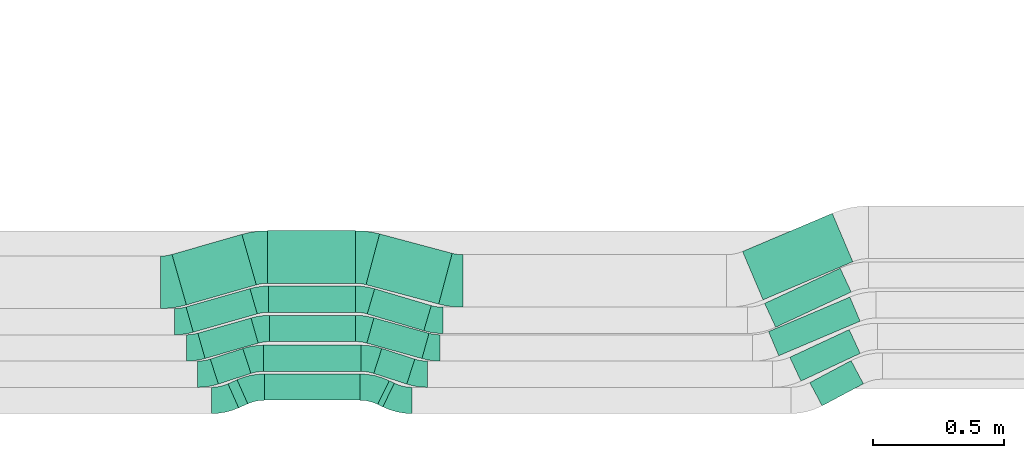
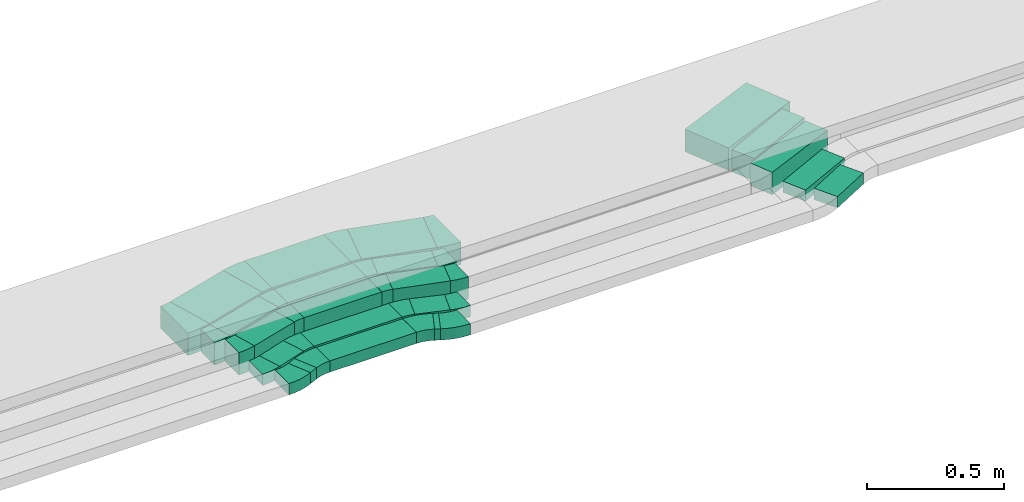
# One storey, part 15 of 28: 20 flow fittings, 20 flow segments.
"""IFC2X3 building model written with IfcOpenShell, lengths in millimetres."""

from ifc_helpers import new_model, entity, si_unit, converted_unit, derived_unit, direction, frame, frame_2d, origin, origin_2d_with_axis, place, context, subcontext, project, spatial, polyline, circle_curve, parameter, trimmed, segment, composite_curve, rectangle, outline, extrude, source, transform, mapped, material, type_object, type_shapes, element, save


model = new_model("IFC2X3")

# Units and contexts
model_context = context("Model", 3, precision=0.01, world=origin(), true_north=direction((6.12303176911189e-17, 1.0)))
body_context = subcontext(model_context, "Body", "Model", "MODEL_VIEW")
ifc_project = project(units=[si_unit("LENGTHUNIT", "METRE", prefix="MILLI"), si_unit("AREAUNIT", "SQUARE_METRE"), si_unit("VOLUMEUNIT", "CUBIC_METRE"), converted_unit("PLANEANGLEUNIT", "DEGREE", entity("IfcRatioMeasure", 0.0174532925199433), si_unit("PLANEANGLEUNIT", "RADIAN"), dimensions=[0, 0, 0, 0, 0, 0, 0]), si_unit("MASSUNIT", "GRAM", prefix="KILO"), derived_unit("MASSDENSITYUNIT", [(si_unit("MASSUNIT", "GRAM", prefix="KILO"), 1), (si_unit("LENGTHUNIT", "METRE"), -3)]), derived_unit("MOMENTOFINERTIAUNIT", [(si_unit("LENGTHUNIT", "METRE"), 4)]), si_unit("TIMEUNIT", "SECOND"), si_unit("FREQUENCYUNIT", "HERTZ"), si_unit("THERMODYNAMICTEMPERATUREUNIT", "DEGREE_CELSIUS"), derived_unit("THERMALTRANSMITTANCEUNIT", [(si_unit("MASSUNIT", "GRAM", prefix="KILO"), 1), (si_unit("THERMODYNAMICTEMPERATUREUNIT", "KELVIN"), -1), (si_unit("TIMEUNIT", "SECOND"), -3)]), derived_unit("VOLUMETRICFLOWRATEUNIT", [(si_unit("LENGTHUNIT", "METRE"), 3), (si_unit("TIMEUNIT", "SECOND"), -1)]), derived_unit("MASSFLOWRATEUNIT", [(si_unit("MASSUNIT", "GRAM", prefix="KILO"), 1), (si_unit("TIMEUNIT", "SECOND"), -1)]), derived_unit("ROTATIONALFREQUENCYUNIT", [(si_unit("TIMEUNIT", "SECOND"), -1)]), si_unit("ELECTRICCURRENTUNIT", "AMPERE"), si_unit("ELECTRICVOLTAGEUNIT", "VOLT"), si_unit("POWERUNIT", "WATT"), si_unit("FORCEUNIT", "NEWTON", prefix="KILO"), si_unit("ILLUMINANCEUNIT", "LUX"), si_unit("LUMINOUSFLUXUNIT", "LUMEN"), si_unit("LUMINOUSINTENSITYUNIT", "CANDELA"), derived_unit("USERDEFINED", [(si_unit("MASSUNIT", "GRAM", prefix="KILO"), -1), (si_unit("LENGTHUNIT", "METRE"), -2), (si_unit("TIMEUNIT", "SECOND"), 3), (si_unit("LUMINOUSFLUXUNIT", "LUMEN"), 1)]), derived_unit("LINEARVELOCITYUNIT", [(si_unit("LENGTHUNIT", "METRE"), 1), (si_unit("TIMEUNIT", "SECOND"), -1)]), si_unit("PRESSUREUNIT", "PASCAL"), derived_unit("USERDEFINED", [(si_unit("LENGTHUNIT", "METRE"), -2), (si_unit("MASSUNIT", "GRAM", prefix="KILO"), 1), (si_unit("TIMEUNIT", "SECOND"), -2)]), derived_unit("LINEARFORCEUNIT", [(si_unit("MASSUNIT", "GRAM", prefix="KILO"), 1), (si_unit("LENGTHUNIT", "METRE"), 1), (si_unit("TIMEUNIT", "SECOND"), -2), (si_unit("LENGTHUNIT", "METRE"), -1)]), derived_unit("PLANARFORCEUNIT", [(si_unit("MASSUNIT", "GRAM", prefix="KILO"), 1), (si_unit("LENGTHUNIT", "METRE"), 1), (si_unit("TIMEUNIT", "SECOND"), -2), (si_unit("LENGTHUNIT", "METRE"), -2)])], contexts=[model_context])

# Site, building, storey
site_placement = place(None, origin())
site = spatial("IfcSite", under=ifc_project, at=site_placement, CompositionType="ELEMENT")
building_placement = place(site_placement, origin())
building = spatial("IfcBuilding", under=site, at=building_placement, CompositionType="ELEMENT")
storey_placement = place(building_placement, frame((0.0, 0.0, 4200.0)))
storey = spatial("IfcBuildingStorey", under=building, at=storey_placement, CompositionType="ELEMENT", Elevation=4200.0)

# Flow segments
cable_carrier_segment_type = type_object("IfcCableCarrierSegmentType", PredefinedType="CABLETRAYSEGMENT")
flow_segment_1_placement = place(storey_placement, frame((34682.3, 268.68, 2836.0)))
element("IfcFlowSegment", 1, at=flow_segment_1_placement, inside=storey, type_object=cable_carrier_segment_type, context=body_context, shape_type="SweptSolid", body=[
    extrude(rectangle(XDim=37.9773753319745, YDim=100.000000000002, at=origin_2d_with_axis()), frame((37.68, 53.4, 0.0), z_axis=(0.0, 0.0, 1.0), x_axis=(0.913545457642342, 0.406736643076381, 0.0)), (0.0, 0.0, 1.0), 49.9999999999995),
])
flow_segment_2_placement = place(storey_placement, frame((34820.59, 297.5, 2836.0)))
element("IfcFlowSegment", 2, at=flow_segment_2_placement, inside=storey, type_object=cable_carrier_segment_type, context=body_context, shape_type="SweptSolid", body=[
    extrude(rectangle(XDim=364.315049440889, YDim=100.0, at=origin_2d_with_axis()), frame((182.16, 50.0, 0.0)), (0.0, 0.0, 1.0), 49.9999999999995),
])
flow_segment_3_placement = place(storey_placement, frame((35252.56, 272.4, 2836.0)))
element("IfcFlowSegment", 3, at=flow_segment_3_placement, inside=storey, type_object=cable_carrier_segment_type, context=body_context, shape_type="SweptSolid", body=[
    extrude(rectangle(XDim=21.632255407363, YDim=99.9999999999977, at=origin_2d_with_axis()), frame((31.64, 49.68, 0.0), z_axis=(0.0, 0.0, 1.0), x_axis=(-0.898794046298938, 0.438371146789548, 0.0)), (0.0, 0.0, 1.0), 49.9999999999995),
])
flow_segment_4_placement = place(storey_placement, frame((34614.95, 359.2, 2836.0)))
element("IfcFlowSegment", 4, at=flow_segment_4_placement, inside=storey, type_object=cable_carrier_segment_type, context=body_context, shape_type="SweptSolid", body=[
    extrude(rectangle(XDim=130.375714038921, YDim=100.0, at=origin_2d_with_axis()), frame((77.45, 67.7, 0.0), z_axis=(0.0, 0.0, 1.0), x_axis=(0.951056516295102, 0.309016994375106, 0.0)), (0.0, 0.0, 1.0), 49.9999999999995),
])
flow_segment_5_placement = place(storey_placement, frame((34818.15, 407.14, 2836.0)))
element("IfcFlowSegment", 5, at=flow_segment_5_placement, inside=storey, type_object=cable_carrier_segment_type, context=body_context, shape_type="SweptSolid", body=[
    extrude(rectangle(XDim=371.2003762548, YDim=100.0, at=origin_2d_with_axis()), frame((185.6, 50.0, 0.0)), (0.0, 0.0, 1.0), 49.9999999999995),
])
flow_segment_6_placement = place(storey_placement, frame((35237.35, 359.03, 2836.0)))
element("IfcFlowSegment", 6, at=flow_segment_6_placement, inside=storey, type_object=cable_carrier_segment_type, context=body_context, shape_type="SweptSolid", body=[
    extrude(rectangle(XDim=132.114181843629, YDim=99.9999999999975, at=origin_2d_with_axis()), frame((78.22, 67.86, 0.0), z_axis=(0.0, 0.0, 1.0), x_axis=(-0.951716267923426, 0.306979063406458, 0.0)), (0.0, 0.0, 1.0), 49.9999999999995),
])
flow_segment_7_placement = place(storey_placement, frame((34567.56, 456.62, 2836.0)))
element("IfcFlowSegment", 7, at=flow_segment_7_placement, inside=storey, type_object=cable_carrier_segment_type, context=body_context, shape_type="SweptSolid", body=[
    extrude(rectangle(XDim=210.504113333605, YDim=100.000000000001, at=origin_2d_with_axis()), frame((114.96, 77.07, 0.0), z_axis=(0.0, 0.0, 1.0), x_axis=(0.961261695938295, 0.275637355817084, 0.0)), (0.0, 0.0, 1.0), 100.000000000001),
])
flow_segment_8_placement = place(storey_placement, frame((34840.78, 520.73, 2836.0)))
element("IfcFlowSegment", 8, at=flow_segment_8_placement, inside=storey, type_object=cable_carrier_segment_type, context=body_context, shape_type="SweptSolid", body=[
    extrude(rectangle(XDim=328.015010459565, YDim=100.0, at=origin_2d_with_axis()), frame((164.01, 50.0, 0.0)), (0.0, 0.0, 1.0), 100.000000000001),
])
flow_segment_9_placement = place(storey_placement, frame((35211.2, 456.18, 2836.0)))
element("IfcFlowSegment", 9, at=flow_segment_9_placement, inside=storey, type_object=cable_carrier_segment_type, context=body_context, shape_type="SweptSolid", body=[
    extrude(rectangle(XDim=217.79615928682, YDim=100.000000000001, at=origin_2d_with_axis()), frame((118.35, 77.51, 0.0), z_axis=(0.0, 0.0, 1.0), x_axis=(-0.962971294356607, 0.269603943304174, 0.0)), (0.0, 0.0, 1.0), 100.000000000001),
])
flow_segment_10_placement = place(storey_placement, frame((34522.66, 556.62, 2836.0)))
element("IfcFlowSegment", 10, at=flow_segment_10_placement, inside=storey, type_object=cable_carrier_segment_type, context=body_context, shape_type="SweptSolid", body=[
    extrude(rectangle(XDim=253.294448744535, YDim=99.9999999999999, at=origin_2d_with_axis()), frame((135.52, 82.97, 0.0), z_axis=(0.0, 0.0, 1.0), x_axis=(0.961261695938265, 0.275637355817187, 0.0)), (0.0, 0.0, 1.0), 100.000000000001),
])
flow_segment_11_placement = place(storey_placement, frame((34837.01, 632.52, 2836.0)))
element("IfcFlowSegment", 11, at=flow_segment_11_placement, inside=storey, type_object=cable_carrier_segment_type, context=body_context, shape_type="SweptSolid", body=[
    extrude(rectangle(XDim=331.015908531008, YDim=100.0, at=origin_2d_with_axis()), frame((165.51, 50.0, 0.0)), (0.0, 0.0, 1.0), 100.000000000001),
])
flow_segment_12_placement = place(storey_placement, frame((35212.58, 562.23, 2836.0)))
element("IfcFlowSegment", 12, at=flow_segment_12_placement, inside=storey, type_object=cable_carrier_segment_type, context=body_context, shape_type="SweptSolid", body=[
    extrude(rectangle(XDim=224.770694209987, YDim=99.9999999999985, at=origin_2d_with_axis()), frame((121.96, 79.86, 0.0), z_axis=(0.0, 0.0, 1.0), x_axis=(0.958832135501793, -0.283973477509911, 0.0)), (0.0, 0.0, 1.0), 100.000000000002),
])
flow_segment_13_placement = place(storey_placement, frame((34468.99, 660.49, 2836.0)))
element("IfcFlowSegment", 13, at=flow_segment_13_placement, inside=storey, type_object=cable_carrier_segment_type, context=body_context, shape_type="SweptSolid", body=[
    extrude(rectangle(XDim=277.030700685204, YDim=200.000000000003, at=origin_2d_with_axis()), frame((160.71, 134.31, 0.0), z_axis=(0.0, 0.0, 1.0), x_axis=(0.961261695938271, 0.275637355817165, 0.0)), (0.0, 0.0, 1.0), 100.000000000001),
])
flow_segment_14_placement = place(storey_placement, frame((34833.73, 742.94, 2836.0)))
element("IfcFlowSegment", 14, at=flow_segment_14_placement, inside=storey, type_object=cable_carrier_segment_type, context=body_context, shape_type="SweptSolid", body=[
    extrude(rectangle(XDim=333.654743209258, YDim=200.0, at=origin_2d_with_axis()), frame((166.83, 100.0, 0.0)), (0.0, 0.0, 1.0), 100.000000000001),
])
flow_segment_15_placement = place(storey_placement, frame((35208.04, 663.76, 2836.0)))
element("IfcFlowSegment", 15, at=flow_segment_15_placement, inside=storey, type_object=cable_carrier_segment_type, context=body_context, shape_type="SweptSolid", body=[
    extrude(rectangle(XDim=286.296046062282, YDim=199.999999999998, at=origin_2d_with_axis()), frame((164.1, 133.54, 0.0), z_axis=(0.0, 0.0, 1.0), x_axis=(0.966162315070978, -0.257934838547816, 0.0)), (0.0, 0.0, 1.0), 100.0),
])
flow_segment_16_placement = place(storey_placement, frame((36897.76, 276.39, 2836.0)))
element("IfcFlowSegment", 16, at=flow_segment_16_placement, inside=storey, type_object=cable_carrier_segment_type, context=body_context, shape_type="SweptSolid", body=[
    extrude(rectangle(XDim=178.268798862719, YDim=99.9999999999956, at=origin_2d_with_axis()), frame((102.17, 85.99, 0.0), z_axis=(0.0, 0.0, 1.0), x_axis=(0.882947592858864, 0.46947156278601, 0.0)), (0.0, 0.0, 1.0), 49.9999999999995),
])
flow_segment_17_placement = place(storey_placement, frame((36821.78, 370.5, 2836.0)))
element("IfcFlowSegment", 17, at=flow_segment_17_placement, inside=storey, type_object=cable_carrier_segment_type, context=body_context, shape_type="SweptSolid", body=[
    extrude(rectangle(XDim=249.322134942816, YDim=100.0, at=origin_2d_with_axis()), frame((134.11, 98.0, 0.0), z_axis=(0.0, 0.0, 1.0), x_axis=(0.906307787036612, 0.422618261740782, 0.0)), (0.0, 0.0, 1.0), 49.9999999999995),
])
flow_segment_18_placement = place(storey_placement, frame((36740.66, 466.92, 2836.0)))
element("IfcFlowSegment", 18, at=flow_segment_18_placement, inside=storey, type_object=cable_carrier_segment_type, context=body_context, shape_type="SweptSolid", body=[
    extrude(rectangle(XDim=336.619080230507, YDim=100.000000000003, at=origin_2d_with_axis()), frame((174.47, 111.79, 0.0), z_axis=(0.0, 0.0, 1.0), x_axis=(0.920504853452414, 0.390731128489335, 0.0)), (0.0, 0.0, 1.0), 99.9999999999989),
])
flow_segment_19_placement = place(storey_placement, frame((36725.7, 575.5, 2836.0)))
element("IfcFlowSegment", 19, at=flow_segment_19_placement, inside=storey, type_object=cable_carrier_segment_type, context=body_context, shape_type="SweptSolid", body=[
    extrude(rectangle(XDim=317.491127027028, YDim=100.000000000002, at=origin_2d_with_axis()), frame((165.0, 112.4, 0.0), z_axis=(0.0, 0.0, 1.0), x_axis=(0.906307787036578, 0.422618261740854, 0.0)), (0.0, 0.0, 1.0), 99.9999999999989),
])
flow_segment_20_placement = place(storey_placement, frame((36641.76, 679.87, 2836.0)))
element("IfcFlowSegment", 20, at=flow_segment_20_placement, inside=storey, type_object=cable_carrier_segment_type, context=body_context, shape_type="SweptSolid", body=[
    extrude(rectangle(XDim=371.273850288119, YDim=200.000000000002, at=origin_2d_with_axis()), frame((209.95, 164.58, 0.0), z_axis=(0.0, 0.0, 1.0), x_axis=(0.920504853452391, 0.390731128489391, 0.0)), (0.0, 0.0, 1.0), 99.9999999999989),
])

# Flow fittings
ifc_material = material()
cable_carrier_fitting_type_1 = type_object("IfcCableCarrierFittingType", Name="470_DKC_S5_Variable Angle Elbow 0-45:-", PredefinedType="NOTDEFINED", material=ifc_material)
shared_shape_1 = source(origin(), body_context, "Body", "SweptSolid", [
    extrude(outline(composite_curve([segment(polyline([(-28.55, -53.94), (-27.55, -53.94)]), True, "CONTINUOUS"), segment(trimmed(circle_curve(frame_2d((-27.55, 196.06), x_axis=(0.0, -1.0)), 250.0), [parameter(0.0)], [parameter(16.0000000000001)], True, "PARAMETER"), True, "CONTINUOUS"), segment(polyline([(41.36, -44.26), (42.32, -43.98)]), True, "CONTINUOUS"), segment(polyline([(42.32, -43.98), (14.75, 52.14)]), True, "CONTINUOUS"), segment(polyline([(14.75, 52.14), (13.79, 51.87)]), True, "CONTINUOUS"), segment(trimmed(circle_curve(frame_2d((-27.55, 196.06), x_axis=(0.0, -1.0)), 150.0), [parameter(0.0)], [parameter(16.0000000000001)], True, "PARAMETER"), False, "CONTINUOUS"), segment(polyline([(-27.55, 46.06), (-28.55, 46.06)]), True, "CONTINUOUS"), segment(polyline([(-28.55, 46.06), (-28.55, -53.94)]), True, "CONTINUOUS")], self_intersect=False)), frame((-0.55, 3.94, -50.0)), (0.0, 0.0, 1.0), 100.0),
])
type_shapes(cable_carrier_fitting_type_1, [shared_shape_1])
flow_fitting_1_placement = place(storey_placement, frame((34553.36, 496.66, 2886.0)))
element("IfcFlowFitting", 21, at=flow_fitting_1_placement, inside=storey, type_object=cable_carrier_fitting_type_1, material=ifc_material, Name="470_DKC_S5_Variable Angle Elbow 0-45:-", ObjectType="470_DKC_S5_Variable Angle Elbow 0-45:-", context=body_context, shape_type="MappedRepresentation", body=[
    mapped(shared_shape_1, transform((0.0, 0.0, 0.0), scale=1.0)),
])
flow_fitting_2_placement = place(storey_placement, frame((34811.67, 570.73, 2886.0), z_axis=(0.0, 0.0, 1.0), x_axis=(-1.0, 0.0, 0.0)))
element("IfcFlowFitting", 22, at=flow_fitting_2_placement, inside=storey, type_object=cable_carrier_fitting_type_1, material=ifc_material, Name="470_DKC_S5_Variable Angle Elbow 0-45:-", ObjectType="470_DKC_S5_Variable Angle Elbow 0-45:-", context=body_context, shape_type="MappedRepresentation", body=[
    mapped(shared_shape_1, transform((0.0, 0.0, 0.0), scale=1.0)),
])
flow_fitting_3_placement = place(storey_placement, frame((34508.46, 596.66, 2886.0)))
element("IfcFlowFitting", 23, at=flow_fitting_3_placement, inside=storey, type_object=cable_carrier_fitting_type_1, material=ifc_material, Name="470_DKC_S5_Variable Angle Elbow 0-45:-", ObjectType="470_DKC_S5_Variable Angle Elbow 0-45:-", context=body_context, shape_type="MappedRepresentation", body=[
    mapped(shared_shape_1, transform((0.0, 0.0, 0.0), scale=1.0)),
])
flow_fitting_4_placement = place(storey_placement, frame((34807.91, 682.52, 2886.0), z_axis=(0.0, 0.0, 1.0), x_axis=(-1.0, 0.0, 0.0)))
element("IfcFlowFitting", 24, at=flow_fitting_4_placement, inside=storey, type_object=cable_carrier_fitting_type_1, material=ifc_material, Name="470_DKC_S5_Variable Angle Elbow 0-45:-", ObjectType="470_DKC_S5_Variable Angle Elbow 0-45:-", context=body_context, shape_type="MappedRepresentation", body=[
    mapped(shared_shape_1, transform((0.0, 0.0, 0.0), scale=1.0)),
])
cable_carrier_fitting_type_2 = type_object("IfcCableCarrierFittingType", Name="470_DKC_S5_Variable Angle Elbow 0-45:-", PredefinedType="NOTDEFINED", material=ifc_material)
shared_shape_2 = source(origin(), body_context, "Body", "SweptSolid", [
    extrude(outline(composite_curve([segment(polyline([(-41.65, -58.75), (-40.65, -58.75)]), True, "CONTINUOUS"), segment(trimmed(circle_curve(frame_2d((-40.65, 191.25), x_axis=(0.0, -1.0)), 250.0), [parameter(0.0)], [parameter(24.0000000000006)], True, "PARAMETER"), True, "CONTINUOUS"), segment(polyline([(61.03, -37.13), (61.95, -36.73)]), True, "CONTINUOUS"), segment(polyline([(61.95, -36.73), (21.27, 54.63)]), True, "CONTINUOUS"), segment(polyline([(21.27, 54.63), (20.36, 54.22)]), True, "CONTINUOUS"), segment(trimmed(circle_curve(frame_2d((-40.65, 191.25), x_axis=(0.0, -1.0)), 150.0), [parameter(0.0)], [parameter(24.0000000000006)], True, "PARAMETER"), False, "CONTINUOUS"), segment(polyline([(-40.65, 41.25), (-41.65, 41.25)]), True, "CONTINUOUS"), segment(polyline([(-41.65, 41.25), (-41.65, -58.75)]), True, "CONTINUOUS")], self_intersect=False)), frame((-1.86, 8.75, -25.0)), (0.0, 0.0, 1.0), 50.0),
])
type_shapes(cable_carrier_fitting_type_2, [shared_shape_2])
flow_fitting_5_placement = place(storey_placement, frame((34662.88, 296.66, 2861.0)))
element("IfcFlowFitting", 25, at=flow_fitting_5_placement, inside=storey, type_object=cable_carrier_fitting_type_2, material=ifc_material, Name="470_DKC_S5_Variable Angle Elbow 0-45:-", ObjectType="470_DKC_S5_Variable Angle Elbow 0-45:-", context=body_context, shape_type="MappedRepresentation", body=[
    mapped(shared_shape_2, transform((0.0, 0.0, 0.0), scale=1.0)),
])
flow_fitting_6_placement = place(storey_placement, frame((34777.08, 347.5, 2861.0), z_axis=(0.0, 0.0, 1.0), x_axis=(-1.0, 0.0, 0.0)))
element("IfcFlowFitting", 26, at=flow_fitting_6_placement, inside=storey, type_object=cable_carrier_fitting_type_2, material=ifc_material, Name="470_DKC_S5_Variable Angle Elbow 0-45:-", ObjectType="470_DKC_S5_Variable Angle Elbow 0-45:-", context=body_context, shape_type="MappedRepresentation", body=[
    mapped(shared_shape_2, transform((0.0, 0.0, 0.0), scale=1.0)),
])
cable_carrier_fitting_type_3 = type_object("IfcCableCarrierFittingType", Name="470_DKC_S5_Variable Angle Elbow 0-45:-", PredefinedType="NOTDEFINED", material=ifc_material)
shared_shape_3 = source(origin(), body_context, "Body", "SweptSolid", [
    extrude(outline(composite_curve([segment(polyline([(-44.81, -60.23), (-43.81, -60.23)]), True, "CONTINUOUS"), segment(trimmed(circle_curve(frame_2d((-43.81, 189.77), x_axis=(0.0, -1.0)), 250.0), [parameter(0.0)], [parameter(26.0000000000001)], True, "PARAMETER"), True, "CONTINUOUS"), segment(polyline([(65.78, -34.93), (66.68, -34.49)]), True, "CONTINUOUS"), segment(polyline([(66.68, -34.49), (22.84, 55.39)]), True, "CONTINUOUS"), segment(polyline([(22.84, 55.39), (21.94, 54.95)]), True, "CONTINUOUS"), segment(trimmed(circle_curve(frame_2d((-43.81, 189.77), x_axis=(0.0, -1.0)), 150.0), [parameter(0.0)], [parameter(26.0000000000001)], True, "PARAMETER"), False, "CONTINUOUS"), segment(polyline([(-43.81, 39.77), (-44.81, 39.77)]), True, "CONTINUOUS"), segment(polyline([(-44.81, 39.77), (-44.81, -60.23)]), True, "CONTINUOUS")], self_intersect=False)), frame((-2.36, 10.23, -25.0)), (0.0, 0.0, 1.0), 50.0),
])
type_shapes(cable_carrier_fitting_type_3, [shared_shape_3])
for number, where, z_axis, x_axis, name in (
    (27, (35336.32, 296.66, 2861.0), (0.0, 0.0, 1.0), (0.898794046299104, -0.438371146789206, 0.0), "470_DKC_S5_Variable Angle Elbow 0-45:-"),
    (28, (35232.08, 347.5, 2861.0), (0.0, 0.0, 1.0), (-0.898794046298929, 0.438371146789566, 0.0), "470_DKC_S5_Variable Angle Elbow 0-45:-"),
):
    element("IfcFlowFitting", number, at=place(storey_placement, frame(where, z_axis=z_axis, x_axis=x_axis)), inside=storey, type_object=cable_carrier_fitting_type_3, material=ifc_material, Name=name, ObjectType="470_DKC_S5_Variable Angle Elbow 0-45:-", context=body_context, shape_type="MappedRepresentation", body=[
        mapped(shared_shape_3, transform((0.0, 0.0, 0.0), scale=1.0)),
    ])
cable_carrier_fitting_type_4 = type_object("IfcCableCarrierFittingType", Name="470_DKC_S5_Variable Angle Elbow 0-45:-", PredefinedType="NOTDEFINED", material=ifc_material)
shared_shape_4 = source(origin(), body_context, "Body", "SweptSolid", [
    extrude(outline(composite_curve([segment(polyline([(-31.89, -54.97), (-30.89, -54.97)]), True, "CONTINUOUS"), segment(trimmed(circle_curve(frame_2d((-30.89, 195.03), x_axis=(0.0, -1.0)), 250.0), [parameter(0.0)], [parameter(18.0)], True, "PARAMETER"), True, "CONTINUOUS"), segment(polyline([(46.36, -42.74), (47.32, -42.43)]), True, "CONTINUOUS"), segment(polyline([(47.32, -42.43), (16.41, 52.68)]), True, "CONTINUOUS"), segment(polyline([(16.41, 52.68), (15.46, 52.37)]), True, "CONTINUOUS"), segment(trimmed(circle_curve(frame_2d((-30.89, 195.03), x_axis=(0.0, -1.0)), 150.0), [parameter(0.0)], [parameter(18.0)], True, "PARAMETER"), False, "CONTINUOUS"), segment(polyline([(-30.89, 45.03), (-31.89, 45.03)]), True, "CONTINUOUS"), segment(polyline([(-31.89, 45.03), (-31.89, -54.97)]), True, "CONTINUOUS")], self_intersect=False)), frame((-0.79, 4.97, -25.0)), (0.0, 0.0, 1.0), 50.0000000000001),
])
type_shapes(cable_carrier_fitting_type_4, [shared_shape_4])
flow_fitting_7_placement = place(storey_placement, frame((34599.32, 396.66, 2861.0)))
element("IfcFlowFitting", 29, at=flow_fitting_7_placement, inside=storey, type_object=cable_carrier_fitting_type_4, material=ifc_material, Name="470_DKC_S5_Variable Angle Elbow 0-45:-", ObjectType="470_DKC_S5_Variable Angle Elbow 0-45:-", context=body_context, shape_type="MappedRepresentation", body=[
    mapped(shared_shape_4, transform((0.0, 0.0, 0.0), scale=1.0)),
])
flow_fitting_8_placement = place(storey_placement, frame((34785.47, 457.14, 2861.0), z_axis=(0.0, 0.0, 1.0), x_axis=(-1.0, 0.0, 0.0)))
element("IfcFlowFitting", 30, at=flow_fitting_8_placement, inside=storey, type_object=cable_carrier_fitting_type_4, material=ifc_material, Name="470_DKC_S5_Variable Angle Elbow 0-45:-", ObjectType="470_DKC_S5_Variable Angle Elbow 0-45:-", context=body_context, shape_type="MappedRepresentation", body=[
    mapped(shared_shape_4, transform((0.0, 0.0, 0.0), scale=1.0)),
])
cable_carrier_fitting_type_5 = type_object("IfcCableCarrierFittingType", Name="470_DKC_S5_Variable Angle Elbow 0-45:-", PredefinedType="NOTDEFINED", material=ifc_material)
shared_shape_5 = source(origin(), body_context, "Body", "SweptSolid", [
    extrude(outline(composite_curve([segment(polyline([(-31.69, -54.91), (-30.69, -54.91)]), True, "CONTINUOUS"), segment(trimmed(circle_curve(frame_2d((-30.69, 195.09), x_axis=(0.0, -1.0)), 250.0), [parameter(0.0)], [parameter(17.8772687945037)], True, "PARAMETER"), True, "CONTINUOUS"), segment(polyline([(46.06, -42.83), (47.01, -42.53)]), True, "CONTINUOUS"), segment(polyline([(47.01, -42.53), (16.31, 52.64)]), True, "CONTINUOUS"), segment(polyline([(16.31, 52.64), (15.36, 52.34)]), True, "CONTINUOUS"), segment(trimmed(circle_curve(frame_2d((-30.69, 195.09), x_axis=(0.0, -1.0)), 150.0), [parameter(0.0)], [parameter(17.8772687945037)], True, "PARAMETER"), False, "CONTINUOUS"), segment(polyline([(-30.69, 45.09), (-31.69, 45.09)]), True, "CONTINUOUS"), segment(polyline([(-31.69, 45.09), (-31.69, -54.91)]), True, "CONTINUOUS")], self_intersect=False)), frame((-0.77, 4.91, -25.0)), (0.0, 0.0, 1.0), 50.0000000000001),
])
type_shapes(cable_carrier_fitting_type_5, [shared_shape_5])
for number, where, z_axis, x_axis, name in (
    (31, (35409.32, 396.66, 2861.0), (0.0, 0.0, 1.0), (0.951716267923469, -0.306979063406325, 0.0), "470_DKC_S5_Variable Angle Elbow 0-45:-"),
    (32, (35221.81, 457.14, 2861.0), (0.0, 0.0, 1.0), (-0.951716267923451, 0.30697906340638, 0.0), "470_DKC_S5_Variable Angle Elbow 0-45:-"),
):
    element("IfcFlowFitting", number, at=place(storey_placement, frame(where, z_axis=z_axis, x_axis=x_axis)), inside=storey, type_object=cable_carrier_fitting_type_5, material=ifc_material, Name=name, ObjectType="470_DKC_S5_Variable Angle Elbow 0-45:-", context=body_context, shape_type="MappedRepresentation", body=[
        mapped(shared_shape_5, transform((0.0, 0.0, 0.0), scale=1.0)),
    ])
cable_carrier_fitting_type_6 = type_object("IfcCableCarrierFittingType", Name="470_DKC_S5_Variable Angle Elbow 0-45:-", PredefinedType="NOTDEFINED", material=ifc_material)
shared_shape_6 = source(origin(), body_context, "Body", "SweptSolid", [
    extrude(outline(composite_curve([segment(polyline([(-27.95, -53.77), (-26.95, -53.77)]), True, "CONTINUOUS"), segment(trimmed(circle_curve(frame_2d((-26.95, 196.23), x_axis=(0.0, -1.0)), 250.0), [parameter(0.0)], [parameter(15.6407005368424)], True, "PARAMETER"), True, "CONTINUOUS"), segment(polyline([(40.45, -44.51), (41.41, -44.24)]), True, "CONTINUOUS"), segment(polyline([(41.41, -44.24), (14.45, 52.05)]), True, "CONTINUOUS"), segment(polyline([(14.45, 52.05), (13.49, 51.78)]), True, "CONTINUOUS"), segment(trimmed(circle_curve(frame_2d((-26.95, 196.23), x_axis=(0.0, -1.0)), 150.0), [parameter(0.0)], [parameter(15.6407005368424)], True, "PARAMETER"), False, "CONTINUOUS"), segment(polyline([(-26.95, 46.23), (-27.95, 46.23)]), True, "CONTINUOUS"), segment(polyline([(-27.95, 46.23), (-27.95, -53.77)]), True, "CONTINUOUS")], self_intersect=False)), frame((-0.52, 3.77, -50.0)), (0.0, 0.0, 1.0), 100.0),
])
type_shapes(cable_carrier_fitting_type_6, [shared_shape_6])
for number, where, z_axis, x_axis, name in (
    (33, (35461.82, 496.66, 2886.0), (0.0, 0.0, 1.0), (0.962971294356626, -0.269603943304108, 0.0), "470_DKC_S5_Variable Angle Elbow 0-45:-"),
    (34, (35197.26, 570.73, 2886.0), (0.0, 0.0, 1.0), (-0.962971294356617, 0.269603943304141, 0.0), "470_DKC_S5_Variable Angle Elbow 0-45:-"),
):
    element("IfcFlowFitting", number, at=place(storey_placement, frame(where, z_axis=z_axis, x_axis=x_axis)), inside=storey, type_object=cable_carrier_fitting_type_6, material=ifc_material, Name=name, ObjectType="470_DKC_S5_Variable Angle Elbow 0-45:-", context=body_context, shape_type="MappedRepresentation", body=[
        mapped(shared_shape_6, transform((0.0, 0.0, 0.0), scale=1.0)),
    ])
cable_carrier_fitting_type_7 = type_object("IfcCableCarrierFittingType", Name="470_DKC_S5_Variable Angle Elbow 0-45:-", PredefinedType="NOTDEFINED", material=ifc_material)
shared_shape_7 = source(origin(), body_context, "Body", "SweptSolid", [
    extrude(outline(composite_curve([segment(polyline([(-29.39, -54.19), (-28.39, -54.19)]), True, "CONTINUOUS"), segment(trimmed(circle_curve(frame_2d((-28.39, 195.81), x_axis=(0.0, -1.0)), 250.0), [parameter(0.0)], [parameter(16.4974981762259)], True, "PARAMETER"), True, "CONTINUOUS"), segment(polyline([(42.61, -43.9), (43.57, -43.61)]), True, "CONTINUOUS"), segment(polyline([(43.57, -43.61), (15.17, 52.27)]), True, "CONTINUOUS"), segment(polyline([(15.17, 52.27), (14.21, 51.99)]), True, "CONTINUOUS"), segment(trimmed(circle_curve(frame_2d((-28.39, 195.81), x_axis=(0.0, -1.0)), 150.0), [parameter(0.0)], [parameter(16.4974981762259)], True, "PARAMETER"), False, "CONTINUOUS"), segment(polyline([(-28.39, 45.81), (-29.39, 45.81)]), True, "CONTINUOUS"), segment(polyline([(-29.39, 45.81), (-29.39, -54.19)]), True, "CONTINUOUS")], self_intersect=False)), frame((-0.61, 4.19, -50.0)), (0.0, 0.0, 1.0), 100.0),
])
type_shapes(cable_carrier_fitting_type_7, [shared_shape_7])
for number, where, z_axis, x_axis, name in (
    (35, (35198.02, 682.52, 2886.0), (0.0, 0.0, 1.0), (-0.95883213550181, 0.283973477509853, 0.0), "470_DKC_S5_Variable Angle Elbow 0-45:-"),
    (36, (35471.06, 601.66, 2886.0), (0.0, 0.0, 1.0), (0.958832135501802, -0.28397347750988, 0.0), "470_DKC_S5_Variable Angle Elbow 0-45:-"),
):
    element("IfcFlowFitting", number, at=place(storey_placement, frame(where, z_axis=z_axis, x_axis=x_axis)), inside=storey, type_object=cable_carrier_fitting_type_7, material=ifc_material, Name=name, ObjectType="470_DKC_S5_Variable Angle Elbow 0-45:-", context=body_context, shape_type="MappedRepresentation", body=[
        mapped(shared_shape_7, transform((0.0, 0.0, 0.0), scale=1.0)),
    ])
cable_carrier_fitting_type_8 = type_object("IfcCableCarrierFittingType", Name="470_DKC_S5_Variable Angle Elbow 0-45:-", PredefinedType="NOTDEFINED", material=ifc_material)
shared_shape_8 = source(origin(), body_context, "Body", "SweptSolid", [
    extrude(outline(composite_curve([segment(polyline([(-35.44, -104.91), (-34.44, -104.91)]), True, "CONTINUOUS"), segment(trimmed(circle_curve(frame_2d((-34.44, 245.09), x_axis=(0.0, -1.0)), 350.0), [parameter(0.0)], [parameter(16.0000000000049)], True, "PARAMETER"), True, "CONTINUOUS"), segment(polyline([(62.03, -91.35), (62.99, -91.08)]), True, "CONTINUOUS"), segment(polyline([(62.99, -91.08), (7.86, 101.18)]), True, "CONTINUOUS"), segment(polyline([(7.86, 101.18), (6.9, 100.9)]), True, "CONTINUOUS"), segment(trimmed(circle_curve(frame_2d((-34.44, 245.09), x_axis=(0.0, -1.0)), 150.0), [parameter(0.0)], [parameter(16.0000000000049)], True, "PARAMETER"), False, "CONTINUOUS"), segment(polyline([(-34.44, 95.09), (-35.44, 95.09)]), True, "CONTINUOUS"), segment(polyline([(-35.44, 95.09), (-35.44, -104.91)]), True, "CONTINUOUS")], self_intersect=False)), frame((-0.69, 4.91, -50.0)), (0.0, 0.0, 1.0), 100.0),
])
type_shapes(cable_carrier_fitting_type_8, [shared_shape_8])
flow_fitting_9_placement = place(storey_placement, frame((34461.82, 746.66, 2886.0)))
element("IfcFlowFitting", 37, at=flow_fitting_9_placement, inside=storey, type_object=cable_carrier_fitting_type_8, material=ifc_material, Name="470_DKC_S5_Variable Angle Elbow 0-45:-", ObjectType="470_DKC_S5_Variable Angle Elbow 0-45:-", context=body_context, shape_type="MappedRepresentation", body=[
    mapped(shared_shape_8, transform((0.0, 0.0, 0.0), scale=1.0)),
])
flow_fitting_10_placement = place(storey_placement, frame((34797.59, 842.94, 2886.0), z_axis=(0.0, 0.0, 1.0), x_axis=(-1.0, 0.0, 0.0)))
element("IfcFlowFitting", 38, at=flow_fitting_10_placement, inside=storey, type_object=cable_carrier_fitting_type_8, material=ifc_material, Name="470_DKC_S5_Variable Angle Elbow 0-45:-", ObjectType="470_DKC_S5_Variable Angle Elbow 0-45:-", context=body_context, shape_type="MappedRepresentation", body=[
    mapped(shared_shape_8, transform((0.0, 0.0, 0.0), scale=1.0)),
])
cable_carrier_fitting_type_9 = type_object("IfcCableCarrierFittingType", Name="470_DKC_S5_Variable Angle Elbow 0-45:-", PredefinedType="NOTDEFINED", material=ifc_material)
shared_shape_9 = source(origin(), body_context, "Body", "SweptSolid", [
    extrude(outline(composite_curve([segment(polyline([(-33.23, -104.29), (-32.23, -104.29)]), True, "CONTINUOUS"), segment(trimmed(circle_curve(frame_2d((-32.23, 245.71), x_axis=(0.0, -1.0)), 350.0), [parameter(0.0)], [parameter(14.9475579822834)], True, "PARAMETER"), True, "CONTINUOUS"), segment(polyline([(58.04, -92.45), (59.01, -92.19)]), True, "CONTINUOUS"), segment(polyline([(59.01, -92.19), (7.42, 101.04)]), True, "CONTINUOUS"), segment(polyline([(7.42, 101.04), (6.46, 100.78)]), True, "CONTINUOUS"), segment(trimmed(circle_curve(frame_2d((-32.23, 245.71), x_axis=(0.0, -1.0)), 150.0), [parameter(0.0)], [parameter(14.9475579822834)], True, "PARAMETER"), False, "CONTINUOUS"), segment(polyline([(-32.23, 95.71), (-33.23, 95.71)]), True, "CONTINUOUS"), segment(polyline([(-33.23, 95.71), (-33.23, -104.29)]), True, "CONTINUOUS")], self_intersect=False)), frame((-0.56, 4.29, -50.0)), (0.0, 0.0, 1.0), 100.0),
])
type_shapes(cable_carrier_fitting_type_9, [shared_shape_9])
for number, where, z_axis, x_axis, name in (
    (39, (35201.18, 842.94, 2886.0), (0.0, 0.0, 1.0), (-0.966162315070992, 0.257934838547763, 0.0), "470_DKC_S5_Variable Angle Elbow 0-45:-"),
    (40, (35543.09, 751.66, 2886.0), (0.0, 0.0, 1.0), (0.966162315070988, -0.25793483854778, 0.0), "470_DKC_S5_Variable Angle Elbow 0-45:-"),
):
    element("IfcFlowFitting", number, at=place(storey_placement, frame(where, z_axis=z_axis, x_axis=x_axis)), inside=storey, type_object=cable_carrier_fitting_type_9, material=ifc_material, Name=name, ObjectType="470_DKC_S5_Variable Angle Elbow 0-45:-", context=body_context, shape_type="MappedRepresentation", body=[
        mapped(shared_shape_9, transform((0.0, 0.0, 0.0), scale=1.0)),
    ])

save(model, "model.ifc")
